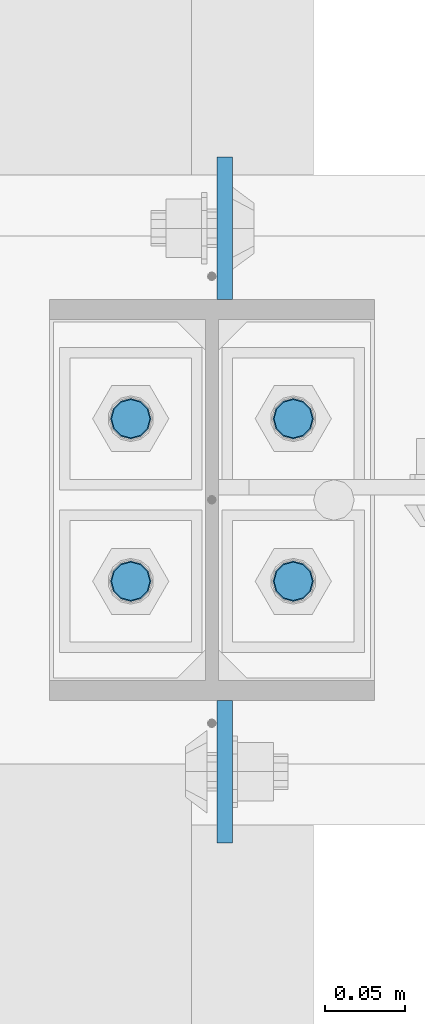
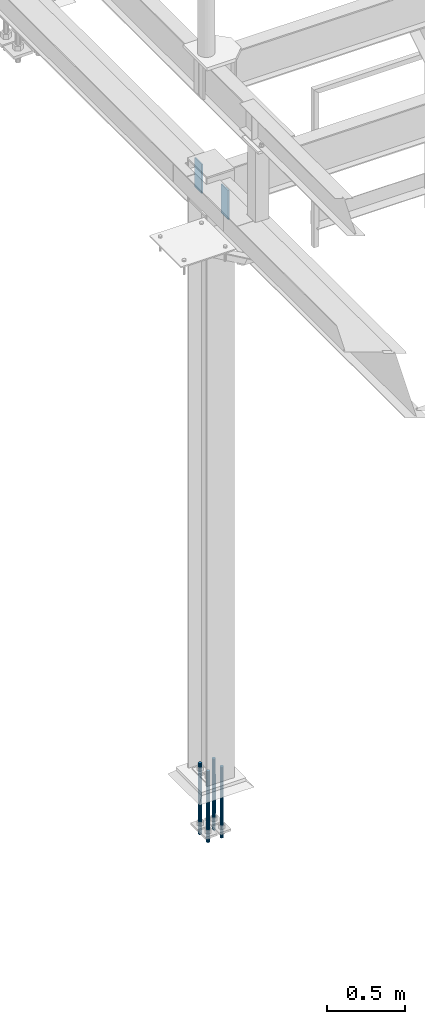
# One storey, part 1452 of 3843: 6 columns, 2 elements without a shape of their own.
"""IFC2X3 building model written with IfcOpenShell, lengths in millimetres."""

from ifc_helpers import new_model, si_unit, frame, origin_with_axes, place, context, subcontext, project, spatial, faceted_brep, material, type_object, element, aggregate, save


model = new_model("IFC2X3")

# Units and contexts
model_context = context("Model", 3, precision=1e-05, world=origin_with_axes())
body_context = subcontext(model_context, "Body", "Model", "MODEL_VIEW")
ifc_project = project(units=[si_unit("LENGTHUNIT", "METRE", prefix="MILLI"), si_unit("AREAUNIT", "SQUARE_METRE"), si_unit("VOLUMEUNIT", "CUBIC_METRE"), si_unit("MASSUNIT", "GRAM", prefix="KILO"), si_unit("TIMEUNIT", "SECOND"), si_unit("PLANEANGLEUNIT", "RADIAN"), si_unit("SOLIDANGLEUNIT", "STERADIAN"), si_unit("THERMODYNAMICTEMPERATUREUNIT", "DEGREE_CELSIUS"), si_unit("LUMINOUSINTENSITYUNIT", "LUMEN")], contexts=[model_context])

# Site, building, storey
site_placement = place(None, origin_with_axes())
site = spatial("IfcSite", under=ifc_project, at=site_placement, CompositionType="ELEMENT")
building_placement = place(site_placement, origin_with_axes())
building = spatial("IfcBuilding", under=site, at=building_placement, Name="Undefined", CompositionType="ELEMENT")
storey_placement = place(building_placement, origin_with_axes())
storey = spatial("IfcBuildingStorey", under=building, at=storey_placement, Name="Undefined", CompositionType="ELEMENT", Elevation=0.0)

# Assembly, columns
assembly_1_placement = place(storey_placement, origin_with_axes())
assembly_1 = element("IfcElementAssembly", 1, at=assembly_1_placement, inside=storey, Name="TEMPLATE", AssemblyPlace="NOTDEFINED", PredefinedType="RIGID_FRAME")
ifc_material_1 = material(Name="Undefined/F1554-GR.55")
column_type_1 = type_object("IfcColumnType", PredefinedType="NOTDEFINED")
column_1_placement = place(assembly_1_placement, frame((33172.4, 25565.1, 30022.8), z_axis=(0.0, -1.0, 0.0), x_axis=(0.0, 0.0, -1.0)))
column_1 = element("IfcColumn", 2, at=column_1_placement, type_object=column_type_1, material=ifc_material_1, Name="ANCHOR_ROD", context=body_context, shape_type="Brep", body=[
    faceted_brep([(-127.0, -10.3923048454162, 6.0), (-127.0, -6.0, 10.3923048454126), (-127.0, 0.0, 12.0), (-127.0, 6.0, 10.3923048454126), (-127.0, 10.3923048454162, 6.0), (-127.0, 12.0, 0.0), (-127.0, 10.3923048454162, -6.0), (-127.0, 6.0, -10.3923048454126), (-127.0, 0.0, -12.0), (-127.0, -6.0, -10.3923048454126), (-127.0, -10.3923048454162, -6.0), (-127.0, -12.0, 0.0), (0.0, 12.0, 0.0), (0.0, 10.3923048454162, -6.0), (0.0, 6.0, -10.3923048454126), (0.0, 0.0, -12.0), (0.0, -6.0, -10.3923048454126), (0.0, -10.3923048454162, -6.0), (0.0, -12.0, 0.0), (0.0, -10.3923048454162, 6.0), (0.0, -6.0, 10.3923048454126), (0.0, 0.0, 12.0), (0.0, 6.0, 10.3923048454126), (0.0, 10.3923048454162, 6.0), (0.0, -10.9985226280696, 6.34999999999854), (0.0, -6.35000000000582, 10.9985226280623), (0.0, 0.0, 12.6999999999971), (0.0, 6.35000000000582, 10.9985226280623), (0.0, 10.9985226280696, 6.34999999999854), (0.0, 12.6999999999971, 0.0), (0.0, 10.9985226280696, -6.34999999999854), (0.0, 6.35000000000582, -10.9985226280623), (0.0, 0.0, -12.6999999999971), (0.0, -6.35000000000582, -10.9985226280623), (0.0, -10.9985226280696, -6.34999999999854), (0.0, -12.6999999999971, 0.0), (304.799999999999, -12.6999999999971, 0.0), (304.799999999999, -10.9985226280623, 6.35000000000036), (304.799999999999, -6.34999999999854, 10.9985226280623), (304.799999999999, 0.0, 12.7000000000007), (304.799999999999, 6.34999999999854, 10.9985226280623), (304.799999999999, 10.9985226280623, 6.35000000000036), (304.799999999999, 12.6999999999971, 0.0), (304.799999999999, 10.9985226280623, -6.35000000000036), (304.799999999999, 6.34999999999854, -10.9985226280623), (304.799999999999, 0.0, -12.7000000000007), (304.799999999999, -6.34999999999854, -10.9985226280623), (304.799999999999, -10.9985226280623, -6.35000000000036), (304.799999999999, -6.0, 10.3923048454126), (304.799999999999, 0.0, 12.0), (304.799999999999, 6.0, 10.3923048454126), (304.799999999999, 10.3923048454162, 6.0), (304.799999999999, 12.0, 0.0), (304.799999999999, 10.3923048454162, -6.0), (304.799999999999, 6.0, -10.3923048454126), (304.799999999999, 0.0, -12.0), (304.799999999999, -6.0, -10.3923048454126), (304.799999999999, -10.3923048454162, -6.0), (304.799999999999, -12.0, 0.0), (304.799999999999, -10.3923048454162, 6.0), (431.799999999999, -6.0, -10.3923048454126), (431.799999999999, 0.0, -12.0), (431.799999999999, 6.0, -10.3923048454126), (431.799999999999, 10.3923048454162, -6.0), (431.799999999999, 12.0, 0.0), (431.799999999999, 10.3923048454162, 6.0), (431.799999999999, 6.0, 10.3923048454126), (431.799999999999, 0.0, 12.0), (431.799999999999, -6.0, 10.3923048454126), (431.799999999999, -10.3923048454162, 6.0), (431.799999999999, -12.0, 0.0), (431.799999999999, -10.3923048454162, -6.0)], [[[0, 1, 2, 3, 4, 5, 6, 7, 8, 9, 10, 11]], [[6, 5, 12, 13]], [[7, 6, 13, 14]], [[8, 7, 14, 15]], [[9, 8, 15, 16]], [[10, 9, 16, 17]], [[11, 10, 17, 18]], [[0, 11, 18, 19]], [[1, 0, 19, 20]], [[2, 1, 20, 21]], [[3, 2, 21, 22]], [[4, 3, 22, 23]], [[5, 4, 23, 12]], [[24, 25, 26, 27, 28, 29, 30, 31, 32, 33, 34, 35], [22, 21, 20, 19, 18, 17, 16, 15, 14, 13, 12, 23]], [[24, 35, 36, 37]], [[25, 24, 37, 38]], [[26, 25, 38, 39]], [[27, 26, 39, 40]], [[28, 27, 40, 41]], [[29, 28, 41, 42]], [[30, 29, 42, 43]], [[31, 30, 43, 44]], [[32, 31, 44, 45]], [[33, 32, 45, 46]], [[34, 33, 46, 47]], [[35, 34, 47, 36]], [[46, 45, 44, 43, 42, 41, 40, 39, 38, 37, 36, 47], [48, 49, 50, 51, 52, 53, 54, 55, 56, 57, 58, 59]], [[60, 61, 62, 63, 64, 65, 66, 67, 68, 69, 70, 71]], [[68, 67, 49, 48]], [[69, 68, 48, 59]], [[70, 69, 59, 58]], [[71, 70, 58, 57]], [[60, 71, 57, 56]], [[61, 60, 56, 55]], [[62, 61, 55, 54]], [[63, 62, 54, 53]], [[64, 63, 53, 52]], [[65, 64, 52, 51]], [[66, 65, 51, 50]], [[67, 66, 50, 49]]]),
])
column_2_placement = place(assembly_1_placement, frame((33274.0, 25565.1, 30022.8), z_axis=(0.0, 1.0, 0.0), x_axis=(0.0, 0.0, -1.0)))
column_2 = element("IfcColumn", 3, at=column_2_placement, type_object=column_type_1, material=ifc_material_1, Name="ANCHOR_ROD", context=body_context, shape_type="Brep", body=[
    faceted_brep([(-127.0, -10.3923048454162, 6.0), (-127.0, -6.0, 10.3923048454126), (-127.0, 0.0, 12.0), (-127.0, 6.0, 10.3923048454126), (-127.0, 10.3923048454162, 6.0), (-127.0, 12.0, 0.0), (-127.0, 10.3923048454162, -6.0), (-127.0, 6.0, -10.3923048454126), (-127.0, 0.0, -12.0), (-127.0, -6.0, -10.3923048454126), (-127.0, -10.3923048454162, -6.0), (-127.0, -12.0, 0.0), (0.0, 12.0, 0.0), (0.0, 10.3923048454162, -6.0), (0.0, 6.0, -10.3923048454126), (0.0, 0.0, -12.0), (0.0, -6.0, -10.3923048454126), (0.0, -10.3923048454162, -6.0), (0.0, -12.0, 0.0), (0.0, -10.3923048454162, 6.0), (0.0, -6.0, 10.3923048454126), (0.0, 0.0, 12.0), (0.0, 6.0, 10.3923048454126), (0.0, 10.3923048454162, 6.0), (0.0, -10.9985226280696, 6.34999999999854), (0.0, -6.35000000000582, 10.9985226280623), (0.0, 0.0, 12.6999999999971), (0.0, 6.35000000000582, 10.9985226280623), (0.0, 10.9985226280696, 6.34999999999854), (0.0, 12.6999999999971, 0.0), (0.0, 10.9985226280696, -6.34999999999854), (0.0, 6.35000000000582, -10.9985226280623), (0.0, 0.0, -12.6999999999971), (0.0, -6.35000000000582, -10.9985226280623), (0.0, -10.9985226280696, -6.34999999999854), (0.0, -12.6999999999971, 0.0), (304.799999999999, -12.6999999999971, 0.0), (304.799999999999, -10.9985226280623, 6.35000000000036), (304.799999999999, -6.34999999999854, 10.9985226280623), (304.799999999999, 0.0, 12.7000000000007), (304.799999999999, 6.34999999999854, 10.9985226280623), (304.799999999999, 10.9985226280623, 6.35000000000036), (304.799999999999, 12.6999999999971, 0.0), (304.799999999999, 10.9985226280623, -6.35000000000036), (304.799999999999, 6.34999999999854, -10.9985226280623), (304.799999999999, 0.0, -12.7000000000007), (304.799999999999, -6.34999999999854, -10.9985226280623), (304.799999999999, -10.9985226280623, -6.35000000000036), (304.799999999999, -6.0, 10.3923048454126), (304.799999999999, 0.0, 12.0), (304.799999999999, 6.0, 10.3923048454126), (304.799999999999, 10.3923048454162, 6.0), (304.799999999999, 12.0, 0.0), (304.799999999999, 10.3923048454162, -6.0), (304.799999999999, 6.0, -10.3923048454126), (304.799999999999, 0.0, -12.0), (304.799999999999, -6.0, -10.3923048454126), (304.799999999999, -10.3923048454162, -6.0), (304.799999999999, -12.0, 0.0), (304.799999999999, -10.3923048454162, 6.0), (431.799999999999, -6.0, -10.3923048454126), (431.799999999999, 0.0, -12.0), (431.799999999999, 6.0, -10.3923048454126), (431.799999999999, 10.3923048454162, -6.0), (431.799999999999, 12.0, 0.0), (431.799999999999, 10.3923048454162, 6.0), (431.799999999999, 6.0, 10.3923048454126), (431.799999999999, 0.0, 12.0), (431.799999999999, -6.0, 10.3923048454126), (431.799999999999, -10.3923048454162, 6.0), (431.799999999999, -12.0, 0.0), (431.799999999999, -10.3923048454162, -6.0)], [[[0, 1, 2, 3, 4, 5, 6, 7, 8, 9, 10, 11]], [[6, 5, 12, 13]], [[7, 6, 13, 14]], [[8, 7, 14, 15]], [[9, 8, 15, 16]], [[10, 9, 16, 17]], [[11, 10, 17, 18]], [[0, 11, 18, 19]], [[1, 0, 19, 20]], [[2, 1, 20, 21]], [[3, 2, 21, 22]], [[4, 3, 22, 23]], [[5, 4, 23, 12]], [[24, 25, 26, 27, 28, 29, 30, 31, 32, 33, 34, 35], [22, 21, 20, 19, 18, 17, 16, 15, 14, 13, 12, 23]], [[24, 35, 36, 37]], [[25, 24, 37, 38]], [[26, 25, 38, 39]], [[27, 26, 39, 40]], [[28, 27, 40, 41]], [[29, 28, 41, 42]], [[30, 29, 42, 43]], [[31, 30, 43, 44]], [[32, 31, 44, 45]], [[33, 32, 45, 46]], [[34, 33, 46, 47]], [[35, 34, 47, 36]], [[46, 45, 44, 43, 42, 41, 40, 39, 38, 37, 36, 47], [48, 49, 50, 51, 52, 53, 54, 55, 56, 57, 58, 59]], [[60, 61, 62, 63, 64, 65, 66, 67, 68, 69, 70, 71]], [[68, 67, 49, 48]], [[69, 68, 48, 59]], [[70, 69, 59, 58]], [[71, 70, 58, 57]], [[60, 71, 57, 56]], [[61, 60, 56, 55]], [[62, 61, 55, 54]], [[63, 62, 54, 53]], [[64, 63, 53, 52]], [[65, 64, 52, 51]], [[66, 65, 51, 50]], [[67, 66, 50, 49]]]),
])
column_3_placement = place(assembly_1_placement, frame((33172.4, 25666.7, 30022.8), z_axis=(0.0, -1.0, 0.0), x_axis=(0.0, 0.0, -1.0)))
column_3 = element("IfcColumn", 4, at=column_3_placement, type_object=column_type_1, material=ifc_material_1, Name="ANCHOR_ROD", context=body_context, shape_type="Brep", body=[
    faceted_brep([(-127.0, -10.3923048454162, 6.0), (-127.0, -6.0, 10.3923048454126), (-127.0, 0.0, 12.0), (-127.0, 6.0, 10.3923048454126), (-127.0, 10.3923048454162, 6.0), (-127.0, 12.0, 0.0), (-127.0, 10.3923048454162, -6.0), (-127.0, 6.0, -10.3923048454126), (-127.0, 0.0, -12.0), (-127.0, -6.0, -10.3923048454126), (-127.0, -10.3923048454162, -6.0), (-127.0, -12.0, 0.0), (0.0, 12.0, 0.0), (0.0, 10.3923048454162, -6.0), (0.0, 6.0, -10.3923048454126), (0.0, 0.0, -12.0), (0.0, -6.0, -10.3923048454126), (0.0, -10.3923048454162, -6.0), (0.0, -12.0, 0.0), (0.0, -10.3923048454162, 6.0), (0.0, -6.0, 10.3923048454126), (0.0, 0.0, 12.0), (0.0, 6.0, 10.3923048454126), (0.0, 10.3923048454162, 6.0), (0.0, -10.9985226280696, 6.34999999999854), (0.0, -6.35000000000582, 10.9985226280623), (0.0, 0.0, 12.6999999999971), (0.0, 6.35000000000582, 10.9985226280623), (0.0, 10.9985226280696, 6.34999999999854), (0.0, 12.6999999999971, 0.0), (0.0, 10.9985226280696, -6.34999999999854), (0.0, 6.35000000000582, -10.9985226280623), (0.0, 0.0, -12.6999999999971), (0.0, -6.35000000000582, -10.9985226280623), (0.0, -10.9985226280696, -6.34999999999854), (0.0, -12.6999999999971, 0.0), (304.799999999999, -12.6999999999971, 0.0), (304.799999999999, -10.9985226280623, 6.35000000000036), (304.799999999999, -6.34999999999854, 10.9985226280623), (304.799999999999, 0.0, 12.7000000000007), (304.799999999999, 6.34999999999854, 10.9985226280623), (304.799999999999, 10.9985226280623, 6.35000000000036), (304.799999999999, 12.6999999999971, 0.0), (304.799999999999, 10.9985226280623, -6.35000000000036), (304.799999999999, 6.34999999999854, -10.9985226280623), (304.799999999999, 0.0, -12.7000000000007), (304.799999999999, -6.34999999999854, -10.9985226280623), (304.799999999999, -10.9985226280623, -6.35000000000036), (304.799999999999, -6.0, 10.3923048454126), (304.799999999999, 0.0, 12.0), (304.799999999999, 6.0, 10.3923048454126), (304.799999999999, 10.3923048454162, 6.0), (304.799999999999, 12.0, 0.0), (304.799999999999, 10.3923048454162, -6.0), (304.799999999999, 6.0, -10.3923048454126), (304.799999999999, 0.0, -12.0), (304.799999999999, -6.0, -10.3923048454126), (304.799999999999, -10.3923048454162, -6.0), (304.799999999999, -12.0, 0.0), (304.799999999999, -10.3923048454162, 6.0), (431.799999999999, -6.0, -10.3923048454126), (431.799999999999, 0.0, -12.0), (431.799999999999, 6.0, -10.3923048454126), (431.799999999999, 10.3923048454162, -6.0), (431.799999999999, 12.0, 0.0), (431.799999999999, 10.3923048454162, 6.0), (431.799999999999, 6.0, 10.3923048454126), (431.799999999999, 0.0, 12.0), (431.799999999999, -6.0, 10.3923048454126), (431.799999999999, -10.3923048454162, 6.0), (431.799999999999, -12.0, 0.0), (431.799999999999, -10.3923048454162, -6.0)], [[[0, 1, 2, 3, 4, 5, 6, 7, 8, 9, 10, 11]], [[6, 5, 12, 13]], [[7, 6, 13, 14]], [[8, 7, 14, 15]], [[9, 8, 15, 16]], [[10, 9, 16, 17]], [[11, 10, 17, 18]], [[0, 11, 18, 19]], [[1, 0, 19, 20]], [[2, 1, 20, 21]], [[3, 2, 21, 22]], [[4, 3, 22, 23]], [[5, 4, 23, 12]], [[24, 25, 26, 27, 28, 29, 30, 31, 32, 33, 34, 35], [22, 21, 20, 19, 18, 17, 16, 15, 14, 13, 12, 23]], [[24, 35, 36, 37]], [[25, 24, 37, 38]], [[26, 25, 38, 39]], [[27, 26, 39, 40]], [[28, 27, 40, 41]], [[29, 28, 41, 42]], [[30, 29, 42, 43]], [[31, 30, 43, 44]], [[32, 31, 44, 45]], [[33, 32, 45, 46]], [[34, 33, 46, 47]], [[35, 34, 47, 36]], [[46, 45, 44, 43, 42, 41, 40, 39, 38, 37, 36, 47], [48, 49, 50, 51, 52, 53, 54, 55, 56, 57, 58, 59]], [[60, 61, 62, 63, 64, 65, 66, 67, 68, 69, 70, 71]], [[68, 67, 49, 48]], [[69, 68, 48, 59]], [[70, 69, 59, 58]], [[71, 70, 58, 57]], [[60, 71, 57, 56]], [[61, 60, 56, 55]], [[62, 61, 55, 54]], [[63, 62, 54, 53]], [[64, 63, 53, 52]], [[65, 64, 52, 51]], [[66, 65, 51, 50]], [[67, 66, 50, 49]]]),
])
column_4_placement = place(assembly_1_placement, frame((33274.0, 25666.7, 30022.8), z_axis=(0.0, 1.0, 0.0), x_axis=(0.0, 0.0, -1.0)))
column_4 = element("IfcColumn", 5, at=column_4_placement, type_object=column_type_1, material=ifc_material_1, Name="ANCHOR_ROD", context=body_context, shape_type="Brep", body=[
    faceted_brep([(-127.0, -10.3923048454162, 6.0), (-127.0, -6.0, 10.3923048454126), (-127.0, 0.0, 12.0), (-127.0, 6.0, 10.3923048454126), (-127.0, 10.3923048454162, 6.0), (-127.0, 12.0, 0.0), (-127.0, 10.3923048454162, -6.0), (-127.0, 6.0, -10.3923048454126), (-127.0, 0.0, -12.0), (-127.0, -6.0, -10.3923048454126), (-127.0, -10.3923048454162, -6.0), (-127.0, -12.0, 0.0), (0.0, 12.0, 0.0), (0.0, 10.3923048454162, -6.0), (0.0, 6.0, -10.3923048454126), (0.0, 0.0, -12.0), (0.0, -6.0, -10.3923048454126), (0.0, -10.3923048454162, -6.0), (0.0, -12.0, 0.0), (0.0, -10.3923048454162, 6.0), (0.0, -6.0, 10.3923048454126), (0.0, 0.0, 12.0), (0.0, 6.0, 10.3923048454126), (0.0, 10.3923048454162, 6.0), (0.0, -10.9985226280696, 6.34999999999854), (0.0, -6.35000000000582, 10.9985226280623), (0.0, 0.0, 12.6999999999971), (0.0, 6.35000000000582, 10.9985226280623), (0.0, 10.9985226280696, 6.34999999999854), (0.0, 12.6999999999971, 0.0), (0.0, 10.9985226280696, -6.34999999999854), (0.0, 6.35000000000582, -10.9985226280623), (0.0, 0.0, -12.6999999999971), (0.0, -6.35000000000582, -10.9985226280623), (0.0, -10.9985226280696, -6.34999999999854), (0.0, -12.6999999999971, 0.0), (304.799999999999, -12.6999999999971, 0.0), (304.799999999999, -10.9985226280623, 6.35000000000036), (304.799999999999, -6.34999999999854, 10.9985226280623), (304.799999999999, 0.0, 12.7000000000007), (304.799999999999, 6.34999999999854, 10.9985226280623), (304.799999999999, 10.9985226280623, 6.35000000000036), (304.799999999999, 12.6999999999971, 0.0), (304.799999999999, 10.9985226280623, -6.35000000000036), (304.799999999999, 6.34999999999854, -10.9985226280623), (304.799999999999, 0.0, -12.7000000000007), (304.799999999999, -6.34999999999854, -10.9985226280623), (304.799999999999, -10.9985226280623, -6.35000000000036), (304.799999999999, -6.0, 10.3923048454126), (304.799999999999, 0.0, 12.0), (304.799999999999, 6.0, 10.3923048454126), (304.799999999999, 10.3923048454162, 6.0), (304.799999999999, 12.0, 0.0), (304.799999999999, 10.3923048454162, -6.0), (304.799999999999, 6.0, -10.3923048454126), (304.799999999999, 0.0, -12.0), (304.799999999999, -6.0, -10.3923048454126), (304.799999999999, -10.3923048454162, -6.0), (304.799999999999, -12.0, 0.0), (304.799999999999, -10.3923048454162, 6.0), (431.799999999999, -6.0, -10.3923048454126), (431.799999999999, 0.0, -12.0), (431.799999999999, 6.0, -10.3923048454126), (431.799999999999, 10.3923048454162, -6.0), (431.799999999999, 12.0, 0.0), (431.799999999999, 10.3923048454162, 6.0), (431.799999999999, 6.0, 10.3923048454126), (431.799999999999, 0.0, 12.0), (431.799999999999, -6.0, 10.3923048454126), (431.799999999999, -10.3923048454162, 6.0), (431.799999999999, -12.0, 0.0), (431.799999999999, -10.3923048454162, -6.0)], [[[0, 1, 2, 3, 4, 5, 6, 7, 8, 9, 10, 11]], [[6, 5, 12, 13]], [[7, 6, 13, 14]], [[8, 7, 14, 15]], [[9, 8, 15, 16]], [[10, 9, 16, 17]], [[11, 10, 17, 18]], [[0, 11, 18, 19]], [[1, 0, 19, 20]], [[2, 1, 20, 21]], [[3, 2, 21, 22]], [[4, 3, 22, 23]], [[5, 4, 23, 12]], [[24, 25, 26, 27, 28, 29, 30, 31, 32, 33, 34, 35], [22, 21, 20, 19, 18, 17, 16, 15, 14, 13, 12, 23]], [[24, 35, 36, 37]], [[25, 24, 37, 38]], [[26, 25, 38, 39]], [[27, 26, 39, 40]], [[28, 27, 40, 41]], [[29, 28, 41, 42]], [[30, 29, 42, 43]], [[31, 30, 43, 44]], [[32, 31, 44, 45]], [[33, 32, 45, 46]], [[34, 33, 46, 47]], [[35, 34, 47, 36]], [[46, 45, 44, 43, 42, 41, 40, 39, 38, 37, 36, 47], [48, 49, 50, 51, 52, 53, 54, 55, 56, 57, 58, 59]], [[60, 61, 62, 63, 64, 65, 66, 67, 68, 69, 70, 71]], [[68, 67, 49, 48]], [[69, 68, 48, 59]], [[70, 69, 59, 58]], [[71, 70, 58, 57]], [[60, 71, 57, 56]], [[61, 60, 56, 55]], [[62, 61, 55, 54]], [[63, 62, 54, 53]], [[64, 63, 53, 52]], [[65, 64, 52, 51]], [[66, 65, 51, 50]], [[67, 66, 50, 49]]]),
])
aggregate(assembly_1, [column_1, column_2, column_3, column_4])

assembly_2_placement = place(storey_placement, origin_with_axes())
assembly_2 = element("IfcElementAssembly", 6, at=assembly_2_placement, inside=storey, Name="COLUMN", AssemblyPlace="NOTDEFINED", PredefinedType="RIGID_FRAME")
ifc_material_2 = material(Name="STEEL/A572-50")
column_type_2 = type_object("IfcColumnType", PredefinedType="NOTDEFINED")
column_5_placement = place(assembly_2_placement, frame((33231.1374999523, 25785.7625, 34543.9999999999), z_axis=(0.0, -1.0, 0.0), x_axis=(0.0, 0.0, 1.0)))
column_5 = element("IfcColumn", 7, at=column_5_placement, type_object=column_type_2, material=ifc_material_2, Name="PLATE", context=body_context, shape_type="Brep", body=[
    faceted_brep([(0.0, 4.76249999999709, -44.4500000000007), (0.0, 4.76249999999709, 44.4500000000007), (228.599999999999, 4.76249999999709, 44.4500000000007), (228.599999999999, 4.76249999999709, -44.4500000000007), (0.0, -4.76249999999709, 44.4500000000007), (228.599999999999, -4.76249999999709, 44.4500000000007), (0.0, -4.76249999999709, -44.4500000000007), (228.599999999999, -4.76249999999709, -44.4500000000007)], [[[0, 1, 2, 3]], [[1, 4, 5, 2]], [[4, 6, 7, 5]], [[6, 0, 3, 7]], [[5, 7, 3, 2]], [[6, 4, 1, 0]]]),
])
column_6_placement = place(assembly_2_placement, frame((33231.1374999523, 25446.0375, 34544.0), z_axis=(0.0, 1.0, 0.0), x_axis=(0.0, 0.0, 1.0)))
column_6 = element("IfcColumn", 8, at=column_6_placement, type_object=column_type_2, material=ifc_material_2, Name="PLATE", context=body_context, shape_type="Brep", body=[
    faceted_brep([(0.0, 4.76249999999709, -44.4500000000007), (0.0, 4.76249999999709, 44.4500000000007), (228.599999999999, 4.76249999999709, 44.4500000000007), (228.599999999999, 4.76249999999709, -44.4500000000007), (0.0, -4.76249999999709, 44.4500000000007), (228.599999999999, -4.76249999999709, 44.4500000000007), (0.0, -4.76249999999709, -44.4500000000007), (228.599999999999, -4.76249999999709, -44.4500000000007)], [[[0, 1, 2, 3]], [[1, 4, 5, 2]], [[4, 6, 7, 5]], [[6, 0, 3, 7]], [[5, 7, 3, 2]], [[6, 4, 1, 0]]]),
])
aggregate(assembly_2, [column_5, column_6])

save(model, "model.ifc")
